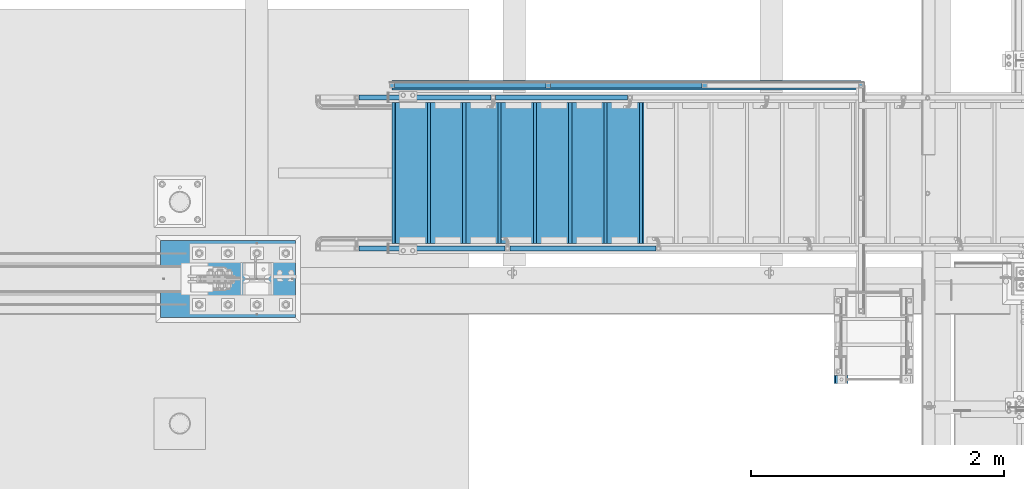
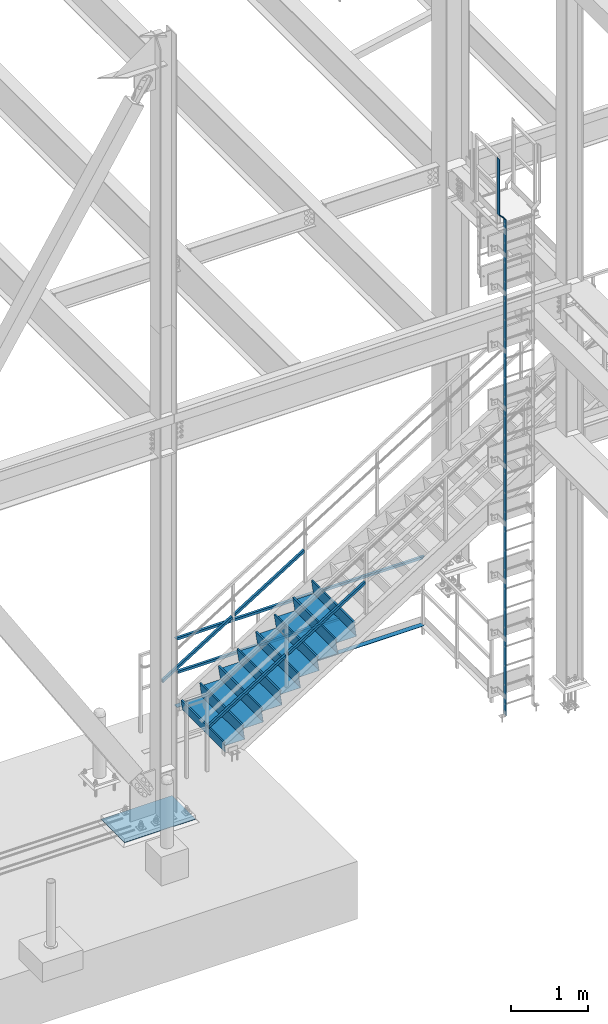
# One storey, part 1881 of 3843: 14 beams, 4 members, 7 elements without a shape of their own.
"""IFC2X3 building model written with IfcOpenShell, lengths in millimetres."""

from ifc_helpers import new_model, si_unit, frame, origin_with_axes, place, context, subcontext, project, spatial, faceted_brep, material, type_object, element, aggregate, save


model = new_model("IFC2X3")

# Units and contexts
model_context = context("Model", 3, precision=1e-05, world=origin_with_axes())
body_context = subcontext(model_context, "Body", "Model", "MODEL_VIEW")
ifc_project = project(units=[si_unit("LENGTHUNIT", "METRE", prefix="MILLI"), si_unit("AREAUNIT", "SQUARE_METRE"), si_unit("VOLUMEUNIT", "CUBIC_METRE"), si_unit("MASSUNIT", "GRAM", prefix="KILO"), si_unit("TIMEUNIT", "SECOND"), si_unit("PLANEANGLEUNIT", "RADIAN"), si_unit("SOLIDANGLEUNIT", "STERADIAN"), si_unit("THERMODYNAMICTEMPERATUREUNIT", "DEGREE_CELSIUS"), si_unit("LUMINOUSINTENSITYUNIT", "LUMEN")], contexts=[model_context])

# Site, building, storey
site_placement = place(None, origin_with_axes())
site = spatial("IfcSite", under=ifc_project, at=site_placement, CompositionType="ELEMENT")
building_placement = place(site_placement, origin_with_axes())
building = spatial("IfcBuilding", under=site, at=building_placement, Name="Undefined", CompositionType="ELEMENT")
storey_placement = place(building_placement, origin_with_axes())
storey = spatial("IfcBuildingStorey", under=building, at=storey_placement, Name="Undefined", CompositionType="ELEMENT", Elevation=0.0)

# Assembly, beams
assembly_1_placement = place(storey_placement, origin_with_axes())
assembly_1 = element("IfcElementAssembly", 1, at=assembly_1_placement, inside=storey, Name="RAIL", AssemblyPlace="NOTDEFINED", PredefinedType="RIGID_FRAME")
ifc_material_1 = material()
beam_type_1 = type_object("IfcBeamType", Name="HSS1-1/2X1-1/2X1/4", PredefinedType="NOTDEFINED")
beam_1_placement = place(assembly_1_placement, frame((32782.9333333604, 90646.2500000096, 31013.4), z_axis=(0.0, 0.0, 1.0), x_axis=(1.0, 0.0, 0.0)))
beam_1 = element("IfcBeam", 2, at=beam_1_placement, type_object=beam_type_1, material=ifc_material_1, Name="RAIL", ObjectType="HSS1-1/2X1-1/2X1/4", context=body_context, shape_type="Brep", body=[
    faceted_brep([(1217.08333333334, -19.0500000000029, 19.0499992350015), (1217.08333333334, -19.0499992349942, -19.0499992350015), (1217.08333333334, 19.0499992349942, -19.0499992350015), (1217.08333333334, 19.0499992349942, 19.0499992350015), (1217.08333333334, -12.6999993299978, 12.6999993300014), (1217.08333333334, 12.6999993299978, 12.6999993300014), (1217.08333333334, 12.6999993299978, -12.6999993300014), (1217.08333333334, -12.6999993299978, -12.6999993300014), (19.0499992350015, 19.0499992350015, -19.0499992350015), (19.0499992350015, 19.0499992350015, 19.0499992350015), (19.0499992350015, -19.0499992350015, 19.0499992350015), (19.0499992350015, -19.0499992350015, -19.0499992350015), (19.0499992350015, 12.6999993299978, 12.6999993299978), (19.0499992350015, -12.6999993299978, 12.6999993299978), (19.0499992350015, -12.6999993299978, -12.6999993299978), (19.0499992350015, 12.6999993299978, -12.6999993299978)], [[[0, 1, 2, 3], [4, 5, 6, 7]], [[8, 9, 3, 2]], [[9, 10, 0, 3]], [[10, 11, 1, 0]], [[11, 8, 2, 1]], [[11, 10, 9, 8], [12, 13, 14, 15]], [[14, 13, 4, 7]], [[15, 14, 7, 6]], [[12, 15, 6, 5]], [[13, 12, 5, 4]]]),
])
beam_2_placement = place(assembly_1_placement, frame((31546.8000000271, 90646.2500000096, 31013.4), z_axis=(0.0, 0.0, 1.0), x_axis=(1.0, 0.0, 0.0)))
beam_2 = element("IfcBeam", 3, at=beam_2_placement, type_object=beam_type_1, material=ifc_material_1, Name="RAIL", ObjectType="HSS1-1/2X1-1/2X1/4", context=body_context, shape_type="Brep", body=[
    faceted_brep([(1217.08333333334, -19.0500000000029, 19.0499992350015), (1217.08333333334, -19.0499992349942, -19.0499992350015), (1217.08333333334, 19.0499992349942, -19.0499992350015), (1217.08333333334, 19.0499992349942, 19.0499992350015), (1217.08333333334, -12.6999993299978, 12.6999993300014), (1217.08333333334, 12.6999993299978, 12.6999993300014), (1217.08333333334, 12.6999993299978, -12.6999993300014), (1217.08333333334, -12.6999993299978, -12.6999993300014), (19.0499992350015, 19.0499992350015, -19.0499992350015), (19.0499992350015, 19.0499992350015, 19.0499992350015), (19.0499992350015, -19.0499992350015, 19.0499992350015), (19.0499992350015, -19.0499992350015, -19.0499992350015), (19.0499992350015, 12.6999993299978, 12.6999993299978), (19.0499992350015, -12.6999993299978, 12.6999993299978), (19.0499992350015, -12.6999993299978, -12.6999993299978), (19.0499992350015, 12.6999993299978, -12.6999993299978)], [[[0, 1, 2, 3], [4, 5, 6, 7]], [[8, 9, 3, 2]], [[9, 10, 0, 3]], [[10, 11, 1, 0]], [[11, 8, 2, 1]], [[11, 10, 9, 8], [12, 13, 14, 15]], [[14, 13, 4, 7]], [[15, 14, 7, 6]], [[12, 15, 6, 5]], [[13, 12, 5, 4]]]),
])
beam_3_placement = place(assembly_1_placement, frame((35274.2499992621, 90646.2500000096, 31546.8), z_axis=(0.0, 0.0, -1.0), x_axis=(-1.0, 0.0, 0.0)))
beam_3 = element("IfcBeam", 4, at=beam_3_placement, type_object=beam_type_1, material=ifc_material_1, Name="RAIL", ObjectType="HSS1-1/2X1-1/2X1/4", context=body_context, shape_type="Brep", body=[
    faceted_brep([(6.34999999999854, 12.6999993299978, -12.6999993299978), (6.34999999999854, -12.6999993299978, -12.6999993299978), (3740.14999856501, -12.6999993299978, -12.6999993300014), (3740.14999856501, 12.6999993299978, -12.6999993300014), (31.7500007135677, -12.6999993300014, 12.6999993299978), (3714.74999990501, -12.6999993299978, 12.6999993300014), (31.7500007135677, 12.6999993300014, 12.6999993299978), (3714.74999990501, 12.6999993299978, 12.6999993300014), (0.0, 19.0500000000029, -19.0499999999993), (38.0999984699883, 19.0499992350015, 19.0499992350015), (3708.40000000001, 19.0499992349942, 19.0499992350015), (3746.49999847001, 19.0499992349942, -19.0499992350015), (38.0999984699883, -19.0499992350015, 19.0499992350015), (3708.40000000001, -19.0499992349942, 19.0499992350015), (0.0, -19.0499992350015, -19.0499992350015), (3746.49999847001, -19.0499992349942, -19.0499992350015)], [[[0, 1, 2, 3]], [[1, 4, 5, 2]], [[4, 6, 7, 5]], [[6, 0, 3, 7]], [[8, 9, 10, 11]], [[9, 12, 13, 10]], [[12, 14, 15, 13]], [[14, 8, 11, 15]], [[13, 15, 11, 10], [5, 7, 3, 2]], [[14, 12, 9, 8], [6, 4, 1, 0]]]),
])
aggregate(assembly_1, [beam_1, beam_2, beam_3])

# Assembly, members
assembly_2_placement = place(storey_placement, origin_with_axes())
assembly_2 = element("IfcElementAssembly", 5, at=assembly_2_placement, inside=storey, Name="RAIL", AssemblyPlace="NOTDEFINED", PredefinedType="RIGID_FRAME")
member_type = type_object("IfcMemberType", Name="HSS1-1/2X1-1/2X1/4", PredefinedType="NOTDEFINED")
member_1_placement = place(assembly_2_placement, frame((32461.2000000437, 89357.2000000455, 31757.5870129148), z_axis=(-0.529007926750979, 0.0, 0.848616882600523), x_axis=(0.848616882600527, 0.0, 0.529007926750974)))
member_1 = element("IfcMember", 6, at=member_1_placement, type_object=member_type, material=ifc_material_1, Name="RAIL", ObjectType="HSS1-1/2X1-1/2X1/4", context=body_context, shape_type="Brep", body=[
    faceted_brep([(1396.18669498301, -19.0500000000029, 19.049999236111), (1372.43604658907, -19.0499992349942, -19.0499992338337), (1372.43604658907, 19.0499992349942, -19.0499992338337), (1396.18669498301, 19.0499992349942, 19.049999236111), (1392.22825348427, -12.6999993299978, 12.6999993311147), (1392.22825348427, 12.6999993299978, 12.6999993311147), (1376.3944880878, 12.6999993299978, -12.6999993288446), (1376.3944880878, -12.6999993299978, -12.6999993288446), (10.5729683018217, 19.0499992350015, -19.0499992349742), (34.3236166958304, 19.0499992350015, 19.0499992349305), (34.3236166958304, -19.0500000222455, 19.0499992349305), (10.5729683018217, -19.0499992350015, -19.0499992349742), (30.3651751973375, -12.6999993299978, 12.6999993299451), (14.5314098008821, -12.6999993299978, -12.6999993299924), (14.5314098008821, 12.6999993299978, -12.6999993299924), (30.3651751973375, 12.6999993299978, 12.6999993299451)], [[[0, 1, 2, 3], [4, 5, 6, 7]], [[8, 9, 3, 2]], [[9, 10, 0, 3]], [[10, 11, 1, 0]], [[11, 8, 2, 1]], [[10, 9, 8, 11], [12, 13, 14, 15]], [[13, 12, 4, 7]], [[14, 13, 7, 6]], [[15, 14, 6, 5]], [[12, 15, 5, 4]]]),
])
member_2_placement = place(assembly_2_placement, frame((31267.4000000013, 89357.2000000455, 31013.3999999981), z_axis=(-0.529007926750979, 0.0, 0.848616882600523), x_axis=(0.848616882600527, 0.0, 0.529007926750974)))
member_2 = element("IfcMember", 7, at=member_2_placement, type_object=member_type, material=ifc_material_1, Name="RAIL", ObjectType="HSS1-1/2X1-1/2X1/4", context=body_context, shape_type="Brep", body=[
    faceted_brep([(1396.18669498301, -19.0500000000029, 19.049999236111), (1372.43604658907, -19.0499992349942, -19.0499992338337), (1372.43604658907, 19.0499992349942, -19.0499992338337), (1396.18669498301, 19.0499992349942, 19.049999236111), (1392.22825348427, -12.6999993299978, 12.6999993311147), (1392.22825348427, 12.6999993299978, 12.6999993311147), (1376.3944880878, 12.6999993299978, -12.6999993288446), (1376.3944880878, -12.6999993299978, -12.6999993288446), (10.5729683018217, 19.0499992350015, -19.0499992349742), (34.3236166958304, 19.0499992350015, 19.0499992349305), (34.3236166958304, -19.0500000222455, 19.0499992349305), (10.5729683018217, -19.0499992350015, -19.0499992349742), (30.3651751973375, -12.6999993299978, 12.6999993299451), (14.5314098008821, -12.6999993299978, -12.6999993299924), (14.5314098008821, 12.6999993299978, -12.6999993299924), (30.3651751973375, 12.6999993299978, 12.6999993299451)], [[[0, 1, 2, 3], [4, 5, 6, 7]], [[8, 9, 3, 2]], [[9, 10, 0, 3]], [[10, 11, 1, 0]], [[11, 8, 2, 1]], [[10, 9, 8, 11], [12, 13, 14, 15]], [[13, 12, 4, 7]], [[14, 13, 7, 6]], [[15, 14, 6, 5]], [[12, 15, 5, 4]]]),
])
aggregate(assembly_2, [member_1, member_2])

assembly_3_placement = place(storey_placement, origin_with_axes())
assembly_3 = element("IfcElementAssembly", 8, at=assembly_3_placement, inside=storey, Name="RAIL", AssemblyPlace="NOTDEFINED", PredefinedType="RIGID_FRAME")
member_3_placement = place(assembly_3_placement, frame((32348.2607143149, 90551.0000000455, 31687.1833023461), z_axis=(-0.529007926750979, 0.0, 0.848616882600523), x_axis=(0.848616882600527, 0.0, 0.529007926750974)))
member_3 = element("IfcMember", 9, at=member_3_placement, type_object=member_type, material=ifc_material_1, Name="RAIL", ObjectType="HSS1-1/2X1-1/2X1/4", context=body_context, shape_type="Brep", body=[
    faceted_brep([(1263.10038948439, -19.0500000000029, 19.0499992359873), (1239.34974109045, -19.0499992349942, -19.0499992339501), (1239.34974109045, 19.0499992349942, -19.0499992339501), (1263.10038948439, 19.0499992349942, 19.0499992359873), (1259.14194798566, -12.6999993299978, 12.6999993309983), (1259.14194798566, 12.6999993299978, 12.6999993309983), (1243.30818258919, 12.6999993299978, -12.699999328961), (1243.30818258919, -12.6999993299978, -12.699999328961), (10.5729683018217, 19.0499992350015, -19.0499992349742), (34.3236166958304, 19.0499992350015, 19.0499992349305), (34.3236166958304, -19.0500000222455, 19.0499992349305), (10.5729683018217, -19.0499992350015, -19.0499992349742), (30.3651751973375, -12.6999993299978, 12.6999993299451), (14.5314098008821, -12.6999993299978, -12.6999993299924), (14.5314098008821, 12.6999993299978, -12.6999993299924), (30.3651751973375, 12.6999993299978, 12.6999993299451)], [[[0, 1, 2, 3], [4, 5, 6, 7]], [[8, 9, 3, 2]], [[9, 10, 0, 3]], [[10, 11, 1, 0]], [[11, 8, 2, 1]], [[10, 9, 8, 11], [12, 13, 14, 15]], [[13, 12, 4, 7]], [[14, 13, 7, 6]], [[15, 14, 6, 5]], [[12, 15, 5, 4]]]),
])
member_4_placement = place(assembly_3_placement, frame((31267.3999999981, 90551.0000000455, 31013.399999998), z_axis=(-0.529007926750979, 0.0, 0.848616882600523), x_axis=(0.848616882600527, 0.0, 0.529007926750974)))
member_4 = element("IfcMember", 10, at=member_4_placement, type_object=member_type, material=ifc_material_1, Name="RAIL", ObjectType="HSS1-1/2X1-1/2X1/4", context=body_context, shape_type="Brep", body=[
    faceted_brep([(1263.10038948439, -19.0500000000029, 19.0499992359873), (1239.34974109045, -19.0499992349942, -19.0499992339501), (1239.34974109045, 19.0499992349942, -19.0499992339501), (1263.10038948439, 19.0499992349942, 19.0499992359873), (1259.14194798566, -12.6999993299978, 12.6999993309983), (1259.14194798566, 12.6999993299978, 12.6999993309983), (1243.30818258919, 12.6999993299978, -12.699999328961), (1243.30818258919, -12.6999993299978, -12.699999328961), (10.5729683018217, 19.0499992350015, -19.0499992349742), (34.3236166958304, 19.0499992350015, 19.0499992349305), (34.3236166958304, -19.0500000222455, 19.0499992349305), (10.5729683018217, -19.0499992350015, -19.0499992349742), (30.3651751973375, -12.6999993299978, 12.6999993299451), (14.5314098008821, -12.6999993299978, -12.6999993299924), (14.5314098008821, 12.6999993299978, -12.6999993299924), (30.3651751973375, 12.6999993299978, 12.6999993299451)], [[[0, 1, 2, 3], [4, 5, 6, 7]], [[8, 9, 3, 2]], [[9, 10, 0, 3]], [[10, 11, 1, 0]], [[11, 8, 2, 1]], [[10, 9, 8, 11], [12, 13, 14, 15]], [[13, 12, 4, 7]], [[14, 13, 7, 6]], [[15, 14, 6, 5]], [[12, 15, 5, 4]]]),
])
aggregate(assembly_3, [member_3, member_4])

# Assembly, beam
assembly_4_placement = place(storey_placement, origin_with_axes())
assembly_4 = element("IfcElementAssembly", 11, at=assembly_4_placement, inside=storey, Name="ref.", AssemblyPlace="NOTDEFINED", PredefinedType="RIGID_FRAME")
ifc_material_2 = material(Name="STEEL/Steel_Undefined")
beam_type_2 = type_object("IfcBeamType", PredefinedType="NOTDEFINED")
beam_4_placement = place(assembly_4_placement, frame((31546.8000000271, 90646.2500000097, 30476.825), z_axis=(0.0, 1.0, 0.0), x_axis=(1.0, 0.0, 0.0)))
beam_4 = element("IfcBeam", 12, at=beam_4_placement, type_object=beam_type_2, material=ifc_material_2, Name="ref.", context=body_context, shape_type="Brep", body=[
    faceted_brep([(0.0, 3.17500000000291, -38.0999999999985), (0.0, 3.17500000000291, 38.0999999999985), (3708.40000000001, 3.17499999999927, 38.1000000000058), (3708.40000000001, 3.17499999999927, -38.1000000000058), (0.0, -3.17500000000291, 38.0999999999985), (3708.40000000001, -3.17499999999927, 38.1000000000058), (0.0, -3.17500000000291, -38.0999999999985), (3708.40000000001, -3.17499999999927, -38.1000000000058)], [[[0, 1, 2, 3]], [[1, 4, 5, 2]], [[4, 6, 7, 5]], [[6, 0, 3, 7]], [[5, 7, 3, 2]], [[6, 4, 1, 0]]]),
])
aggregate(assembly_4, [beam_4])

assembly_5_placement = place(storey_placement, origin_with_axes())
assembly_5 = element("IfcElementAssembly", 13, at=assembly_5_placement, inside=storey, Name="LADDER", AssemblyPlace="NOTDEFINED", PredefinedType="RIGID_FRAME")
ifc_material_3 = material(Name="STEEL/A36")
beam_type_3 = type_object("IfcBeamType", PredefinedType="NOTDEFINED")
beam_5_placement = place(assembly_5_placement, frame((35148.8376798629, 88321.8803589472, 30492.7), z_axis=(0.0, 1.0, 0.0), x_axis=(0.0, 0.0, 1.0)))
beam_5 = element("IfcBeam", 14, at=beam_5_placement, type_object=beam_type_3, material=ifc_material_3, Name="LADDER", context=body_context, shape_type="Brep", body=[
    faceted_brep([(0.0, -4.76249999999709, -31.75), (0.0, -4.76249999999709, 31.75), (0.0, 4.76249999999709, 31.75), (0.0, 4.76249999999709, -31.75), (7869.36876220704, 4.76249999999709, 31.75), (7869.36876220704, 4.76249999999709, -31.75), (7865.42337802544, -4.76249999999709, -31.75), (7865.42337802544, -4.76249999999709, 31.75), (7970.96876220705, -96.8375000000087, 31.75), (7970.96876220705, -96.8375000000087, -31.75), (7967.02337802545, -106.362500000003, -31.75), (7967.02337802545, -106.362500000003, 31.75), (8859.96876220703, -96.8375000000087, 31.75), (8859.96876220703, -96.8375000000087, -31.75), (8859.96876220703, -106.362500000003, 31.75), (8859.96876220703, -106.362500000003, -31.75)], [[[0, 1, 2, 3]], [[3, 2, 4, 5]], [[1, 0, 6, 7]], [[5, 4, 8, 9]], [[7, 6, 10, 11]], [[9, 8, 12, 13]], [[8, 4, 2, 1, 7, 11, 14, 12]], [[11, 10, 15, 14]], [[10, 6, 0, 3, 5, 9, 13, 15]], [[14, 15, 13, 12]]]),
])
aggregate(assembly_5, [beam_5])

# Assembly, beams
assembly_6_placement = place(storey_placement, origin_with_axes())
assembly_6 = element("IfcElementAssembly", 15, at=assembly_6_placement, inside=storey, Name="STAIR", AssemblyPlace="NOTDEFINED", PredefinedType="RIGID_FRAME")
ifc_material_4 = material(Name="STEEL/ASTM A1011")
beam_type_4 = type_object("IfcBeamType", PredefinedType="NOTDEFINED")
beam_6_placement = place(assembly_6_placement, frame((33528.0000000271, 89954.1000000435, 31871.7839285758), z_axis=(0.0, -1.0, 0.0), x_axis=(-1.0, 0.0, 0.0)))
beam_6 = element("IfcBeam", 16, at=beam_6_placement, type_object=beam_type_4, material=ifc_material_4, Name="TREAD", context=body_context, shape_type="Brep", body=[
    faceted_brep([(0.0, -1.58750000000146, -558.799999999999), (0.0, -1.58750000000146, 558.799999999999), (0.0, 1.58750000000146, 558.799999999999), (0.0, 1.58750000000146, -558.799999999999), (21.7283948539116, 1.58750000000146, 558.800000000003), (21.7283948539116, 1.58750000000146, -558.800000000003), (25.3999999999942, -1.58750000000146, -558.799999999999), (25.3999999999942, -1.58750000000146, 558.799999999999), (-11.0799384794227, 226.55892857143, 558.800000000003), (-11.0799384794227, 226.55892857143, -558.800000000003), (-7.40833333332557, 223.383928571428, -558.800000000003), (-7.40833333332557, 223.383928571428, 558.800000000003), (293.720061520566, 226.55892857143, 558.800000000003), (293.720061520566, 226.55892857143, -558.800000000003), (290.974498041134, 223.383928571428, -558.800000000003), (290.974498041134, 223.383928571428, 558.800000000003), (299.614357882056, 186.140896378427, 558.800000000003), (299.614357882056, 186.140896378427, -558.800000000003), (296.472590667174, 185.682721992918, 558.800000000003), (296.472590667174, 185.682721992918, -558.800000000003)], [[[0, 1, 2, 3]], [[3, 2, 4, 5]], [[1, 0, 6, 7]], [[5, 4, 8, 9]], [[7, 6, 10, 11]], [[9, 8, 12, 13]], [[11, 10, 14, 15]], [[13, 12, 16, 17]], [[12, 8, 4, 2, 1, 7, 11, 15, 18, 16]], [[15, 14, 19, 18]], [[14, 10, 6, 0, 3, 5, 9, 13, 17, 19]], [[18, 19, 17, 16]]]),
])
beam_7_placement = place(assembly_6_placement, frame((33248.6000000271, 89954.1000000435, 31697.6125000043), z_axis=(0.0, -1.0, 0.0), x_axis=(-1.0, 0.0, 0.0)))
beam_7 = element("IfcBeam", 17, at=beam_7_placement, type_object=beam_type_4, material=ifc_material_4, Name="TREAD", context=body_context, shape_type="Brep", body=[
    faceted_brep([(0.0, -1.58750000000146, -558.799999999999), (0.0, -1.58750000000146, 558.799999999999), (0.0, 1.58750000000146, 558.799999999999), (0.0, 1.58750000000146, -558.799999999999), (21.7283948539116, 1.58750000000146, 558.800000000003), (21.7283948539116, 1.58750000000146, -558.800000000003), (25.3999999999942, -1.58750000000146, -558.799999999999), (25.3999999999942, -1.58750000000146, 558.799999999999), (-11.0799384794227, 226.55892857143, 558.800000000003), (-11.0799384794227, 226.55892857143, -558.800000000003), (-7.40833333332557, 223.383928571428, -558.800000000003), (-7.40833333332557, 223.383928571428, 558.800000000003), (293.720061520566, 226.55892857143, 558.800000000003), (293.720061520566, 226.55892857143, -558.800000000003), (290.974498041134, 223.383928571428, -558.800000000003), (290.974498041134, 223.383928571428, 558.800000000003), (299.614357882056, 186.140896378427, 558.800000000003), (299.614357882056, 186.140896378427, -558.800000000003), (296.472590667174, 185.682721992918, 558.800000000003), (296.472590667174, 185.682721992918, -558.800000000003)], [[[0, 1, 2, 3]], [[3, 2, 4, 5]], [[1, 0, 6, 7]], [[5, 4, 8, 9]], [[7, 6, 10, 11]], [[9, 8, 12, 13]], [[11, 10, 14, 15]], [[13, 12, 16, 17]], [[12, 8, 4, 2, 1, 7, 11, 15, 18, 16]], [[15, 14, 19, 18]], [[14, 10, 6, 0, 3, 5, 9, 13, 17, 19]], [[18, 19, 17, 16]]]),
])
beam_8_placement = place(assembly_6_placement, frame((32969.2000000271, 89954.1000000435, 31523.4410714329), z_axis=(0.0, -1.0, 0.0), x_axis=(-1.0, 0.0, 0.0)))
beam_8 = element("IfcBeam", 18, at=beam_8_placement, type_object=beam_type_4, material=ifc_material_4, Name="TREAD", context=body_context, shape_type="Brep", body=[
    faceted_brep([(0.0, -1.58750000000146, -558.799999999999), (0.0, -1.58750000000146, 558.799999999999), (0.0, 1.58750000000146, 558.799999999999), (0.0, 1.58750000000146, -558.799999999999), (21.7283948539116, 1.58750000000146, 558.800000000003), (21.7283948539116, 1.58750000000146, -558.800000000003), (25.3999999999942, -1.58750000000146, -558.799999999999), (25.3999999999942, -1.58750000000146, 558.799999999999), (-11.0799384794227, 226.55892857143, 558.800000000003), (-11.0799384794227, 226.55892857143, -558.800000000003), (-7.40833333332557, 223.383928571428, -558.800000000003), (-7.40833333332557, 223.383928571428, 558.800000000003), (293.720061520566, 226.55892857143, 558.800000000003), (293.720061520566, 226.55892857143, -558.800000000003), (290.974498041134, 223.383928571428, -558.800000000003), (290.974498041134, 223.383928571428, 558.800000000003), (299.614357882056, 186.140896378427, 558.800000000003), (299.614357882056, 186.140896378427, -558.800000000003), (296.472590667174, 185.682721992918, 558.800000000003), (296.472590667174, 185.682721992918, -558.800000000003)], [[[0, 1, 2, 3]], [[3, 2, 4, 5]], [[1, 0, 6, 7]], [[5, 4, 8, 9]], [[7, 6, 10, 11]], [[9, 8, 12, 13]], [[11, 10, 14, 15]], [[13, 12, 16, 17]], [[12, 8, 4, 2, 1, 7, 11, 15, 18, 16]], [[15, 14, 19, 18]], [[14, 10, 6, 0, 3, 5, 9, 13, 17, 19]], [[18, 19, 17, 16]]]),
])
beam_9_placement = place(assembly_6_placement, frame((32689.8000000271, 89954.1000000435, 31349.2696428615), z_axis=(0.0, -1.0, 0.0), x_axis=(-1.0, 0.0, 0.0)))
beam_9 = element("IfcBeam", 19, at=beam_9_placement, type_object=beam_type_4, material=ifc_material_4, Name="TREAD", context=body_context, shape_type="Brep", body=[
    faceted_brep([(0.0, -1.58750000000146, -558.799999999999), (0.0, -1.58750000000146, 558.799999999999), (0.0, 1.58750000000146, 558.799999999999), (0.0, 1.58750000000146, -558.799999999999), (21.7283948539116, 1.58750000000146, 558.800000000003), (21.7283948539116, 1.58750000000146, -558.800000000003), (25.3999999999942, -1.58750000000146, -558.799999999999), (25.3999999999942, -1.58750000000146, 558.799999999999), (-11.0799384794227, 226.55892857143, 558.800000000003), (-11.0799384794227, 226.55892857143, -558.800000000003), (-7.40833333332557, 223.383928571428, -558.800000000003), (-7.40833333332557, 223.383928571428, 558.800000000003), (293.720061520566, 226.55892857143, 558.800000000003), (293.720061520566, 226.55892857143, -558.800000000003), (290.974498041134, 223.383928571428, -558.800000000003), (290.974498041134, 223.383928571428, 558.800000000003), (299.614357882056, 186.140896378427, 558.800000000003), (299.614357882056, 186.140896378427, -558.800000000003), (296.472590667174, 185.682721992918, 558.800000000003), (296.472590667174, 185.682721992918, -558.800000000003)], [[[0, 1, 2, 3]], [[3, 2, 4, 5]], [[1, 0, 6, 7]], [[5, 4, 8, 9]], [[7, 6, 10, 11]], [[9, 8, 12, 13]], [[11, 10, 14, 15]], [[13, 12, 16, 17]], [[12, 8, 4, 2, 1, 7, 11, 15, 18, 16]], [[15, 14, 19, 18]], [[14, 10, 6, 0, 3, 5, 9, 13, 17, 19]], [[18, 19, 17, 16]]]),
])
beam_10_placement = place(assembly_6_placement, frame((32410.4000000271, 89954.1000000435, 31175.09821429), z_axis=(0.0, -1.0, 0.0), x_axis=(-1.0, 0.0, 0.0)))
beam_10 = element("IfcBeam", 20, at=beam_10_placement, type_object=beam_type_4, material=ifc_material_4, Name="TREAD", context=body_context, shape_type="Brep", body=[
    faceted_brep([(0.0, -1.58750000000146, -558.799999999999), (0.0, -1.58750000000146, 558.799999999999), (0.0, 1.58750000000146, 558.799999999999), (0.0, 1.58750000000146, -558.799999999999), (21.7283948539116, 1.58750000000146, 558.800000000003), (21.7283948539116, 1.58750000000146, -558.800000000003), (25.3999999999942, -1.58750000000146, -558.799999999999), (25.3999999999942, -1.58750000000146, 558.799999999999), (-11.0799384794227, 226.55892857143, 558.800000000003), (-11.0799384794227, 226.55892857143, -558.800000000003), (-7.40833333332557, 223.383928571428, -558.800000000003), (-7.40833333332557, 223.383928571428, 558.800000000003), (293.720061520566, 226.55892857143, 558.800000000003), (293.720061520566, 226.55892857143, -558.800000000003), (290.974498041134, 223.383928571428, -558.800000000003), (290.974498041134, 223.383928571428, 558.800000000003), (299.614357882056, 186.140896378427, 558.800000000003), (299.614357882056, 186.140896378427, -558.800000000003), (296.472590667174, 185.682721992918, 558.800000000003), (296.472590667174, 185.682721992918, -558.800000000003)], [[[0, 1, 2, 3]], [[3, 2, 4, 5]], [[1, 0, 6, 7]], [[5, 4, 8, 9]], [[7, 6, 10, 11]], [[9, 8, 12, 13]], [[11, 10, 14, 15]], [[13, 12, 16, 17]], [[12, 8, 4, 2, 1, 7, 11, 15, 18, 16]], [[15, 14, 19, 18]], [[14, 10, 6, 0, 3, 5, 9, 13, 17, 19]], [[18, 19, 17, 16]]]),
])
beam_11_placement = place(assembly_6_placement, frame((32131.0000000271, 89954.1000000435, 31000.9267857186), z_axis=(0.0, -1.0, 0.0), x_axis=(-1.0, 0.0, 0.0)))
beam_11 = element("IfcBeam", 21, at=beam_11_placement, type_object=beam_type_4, material=ifc_material_4, Name="TREAD", context=body_context, shape_type="Brep", body=[
    faceted_brep([(0.0, -1.58750000000146, -558.799999999999), (0.0, -1.58750000000146, 558.799999999999), (0.0, 1.58750000000146, 558.799999999999), (0.0, 1.58750000000146, -558.799999999999), (21.7283948539116, 1.58750000000146, 558.800000000003), (21.7283948539116, 1.58750000000146, -558.800000000003), (25.3999999999942, -1.58750000000146, -558.799999999999), (25.3999999999942, -1.58750000000146, 558.799999999999), (-11.0799384794227, 226.55892857143, 558.800000000003), (-11.0799384794227, 226.55892857143, -558.800000000003), (-7.40833333332557, 223.383928571428, -558.800000000003), (-7.40833333332557, 223.383928571428, 558.800000000003), (293.720061520566, 226.55892857143, 558.800000000003), (293.720061520566, 226.55892857143, -558.800000000003), (290.974498041134, 223.383928571428, -558.800000000003), (290.974498041134, 223.383928571428, 558.800000000003), (299.614357882056, 186.140896378427, 558.800000000003), (299.614357882056, 186.140896378427, -558.800000000003), (296.472590667174, 185.682721992918, 558.800000000003), (296.472590667174, 185.682721992918, -558.800000000003)], [[[0, 1, 2, 3]], [[3, 2, 4, 5]], [[1, 0, 6, 7]], [[5, 4, 8, 9]], [[7, 6, 10, 11]], [[9, 8, 12, 13]], [[11, 10, 14, 15]], [[13, 12, 16, 17]], [[12, 8, 4, 2, 1, 7, 11, 15, 18, 16]], [[15, 14, 19, 18]], [[14, 10, 6, 0, 3, 5, 9, 13, 17, 19]], [[18, 19, 17, 16]]]),
])
beam_12_placement = place(assembly_6_placement, frame((31851.6000000271, 89954.1000000435, 30826.7553571472), z_axis=(0.0, -1.0, 0.0), x_axis=(-1.0, 0.0, 0.0)))
beam_12 = element("IfcBeam", 22, at=beam_12_placement, type_object=beam_type_4, material=ifc_material_4, Name="TREAD", context=body_context, shape_type="Brep", body=[
    faceted_brep([(0.0, -1.58750000000146, -558.799999999999), (0.0, -1.58750000000146, 558.799999999999), (0.0, 1.58750000000146, 558.799999999999), (0.0, 1.58750000000146, -558.799999999999), (21.7283948539116, 1.58750000000146, 558.800000000003), (21.7283948539116, 1.58750000000146, -558.800000000003), (25.3999999999942, -1.58750000000146, -558.799999999999), (25.3999999999942, -1.58750000000146, 558.799999999999), (-11.0799384794227, 226.55892857143, 558.800000000003), (-11.0799384794227, 226.55892857143, -558.800000000003), (-7.40833333332557, 223.383928571428, -558.800000000003), (-7.40833333332557, 223.383928571428, 558.800000000003), (293.720061520566, 226.55892857143, 558.800000000003), (293.720061520566, 226.55892857143, -558.800000000003), (290.974498041134, 223.383928571428, -558.800000000003), (290.974498041134, 223.383928571428, 558.800000000003), (299.614357882056, 186.140896378427, 558.800000000003), (299.614357882056, 186.140896378427, -558.800000000003), (296.472590667174, 185.682721992918, 558.800000000003), (296.472590667174, 185.682721992918, -558.800000000003)], [[[0, 1, 2, 3]], [[3, 2, 4, 5]], [[1, 0, 6, 7]], [[5, 4, 8, 9]], [[7, 6, 10, 11]], [[9, 8, 12, 13]], [[11, 10, 14, 15]], [[13, 12, 16, 17]], [[12, 8, 4, 2, 1, 7, 11, 15, 18, 16]], [[15, 14, 19, 18]], [[14, 10, 6, 0, 3, 5, 9, 13, 17, 19]], [[18, 19, 17, 16]]]),
])
beam_type_5 = type_object("IfcBeamType", PredefinedType="NOTDEFINED")
beam_13_placement = place(assembly_6_placement, frame((31572.2000000271, 89954.1000000435, 30652.5839285758), z_axis=(0.0, -1.0, 0.0), x_axis=(-1.0, 0.0, 0.0)))
beam_13 = element("IfcBeam", 23, at=beam_13_placement, type_object=beam_type_5, material=ifc_material_4, Name="TREAD", context=body_context, shape_type="Brep", body=[
    faceted_brep([(0.0, -1.58750000000146, -558.799999999999), (0.0, -1.58750000000146, 558.799999999999), (0.0, 1.58750000000146, 558.799999999999), (0.0, 1.58750000000146, -558.799999999999), (21.7283948539116, 1.58750000000146, 558.800000000003), (21.7283948539116, 1.58750000000146, -558.800000000003), (25.3999999999942, -1.58750000000146, -558.799999999999), (25.3999999999942, -1.58750000000146, 558.799999999999), (-1.81885054821032, 163.054325614496, 558.800000000003), (-1.81885054821032, 163.054325614496, -558.800000000003), (1.32291666666424, 163.512499999997, 558.800000000003), (1.32291666666424, 163.512499999997, -558.800000000003)], [[[0, 1, 2, 3]], [[3, 2, 4, 5]], [[1, 0, 6, 7]], [[5, 4, 8, 9]], [[4, 2, 1, 7, 10, 8]], [[7, 6, 11, 10]], [[6, 0, 3, 5, 9, 11]], [[10, 11, 9, 8]]]),
])
aggregate(assembly_6, [beam_6, beam_7, beam_8, beam_9, beam_10, beam_11, beam_12, beam_13])

# Assembly, beam
assembly_7_placement = place(storey_placement, origin_with_axes())
assembly_7 = element("IfcElementAssembly", 24, at=assembly_7_placement, inside=storey, Name="TEMPLATE", AssemblyPlace="NOTDEFINED", PredefinedType="RIGID_FRAME")
ifc_material_5 = material(Name="STEEL/A572-50")
beam_type_6 = type_object("IfcBeamType", PredefinedType="NOTDEFINED")
beam_14_placement = place(assembly_7_placement, frame((30784.8000061035, 89115.9, 30065.6625), z_axis=(0.0, -1.0, 0.0), x_axis=(-1.0, 0.0, 0.0)))
beam_14 = element("IfcBeam", 25, at=beam_14_placement, type_object=beam_type_6, material=ifc_material_5, Name="TEMPLATE", context=body_context, shape_type="Brep", body=[
    faceted_brep([(0.0, 4.76250000000073, -304.800000000003), (0.0, 4.76250000000073, 304.800000000003), (1066.80001220703, 4.76250000000073, 304.800000000003), (1066.80001220703, 4.76250000000073, -304.800000000003), (0.0, -4.76250000000073, 304.800000000003), (1066.80001220703, -4.76250000000073, 304.800000000003), (0.0, -4.76250000000073, -304.800000000003), (1066.80001220703, -4.76250000000073, -304.800000000003)], [[[0, 1, 2, 3]], [[1, 4, 5, 2]], [[4, 6, 7, 5]], [[6, 0, 3, 7]], [[5, 7, 3, 2]], [[6, 4, 1, 0]]]),
])
aggregate(assembly_7, [beam_14])

save(model, "model.ifc")
